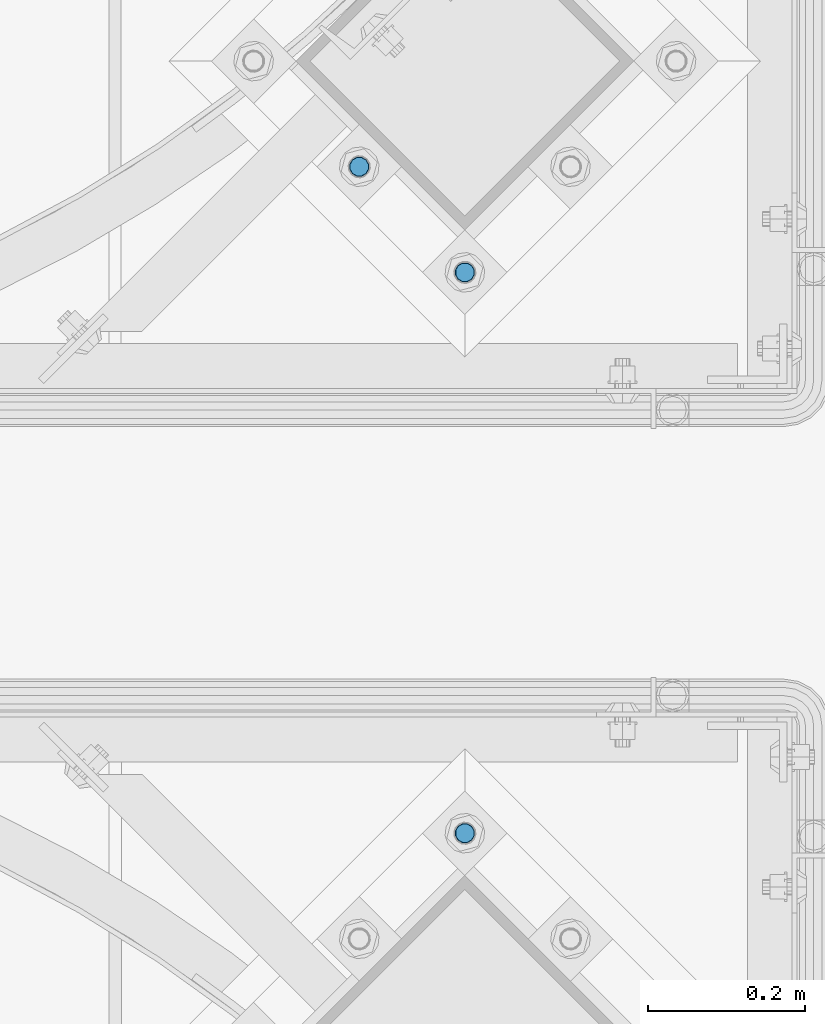
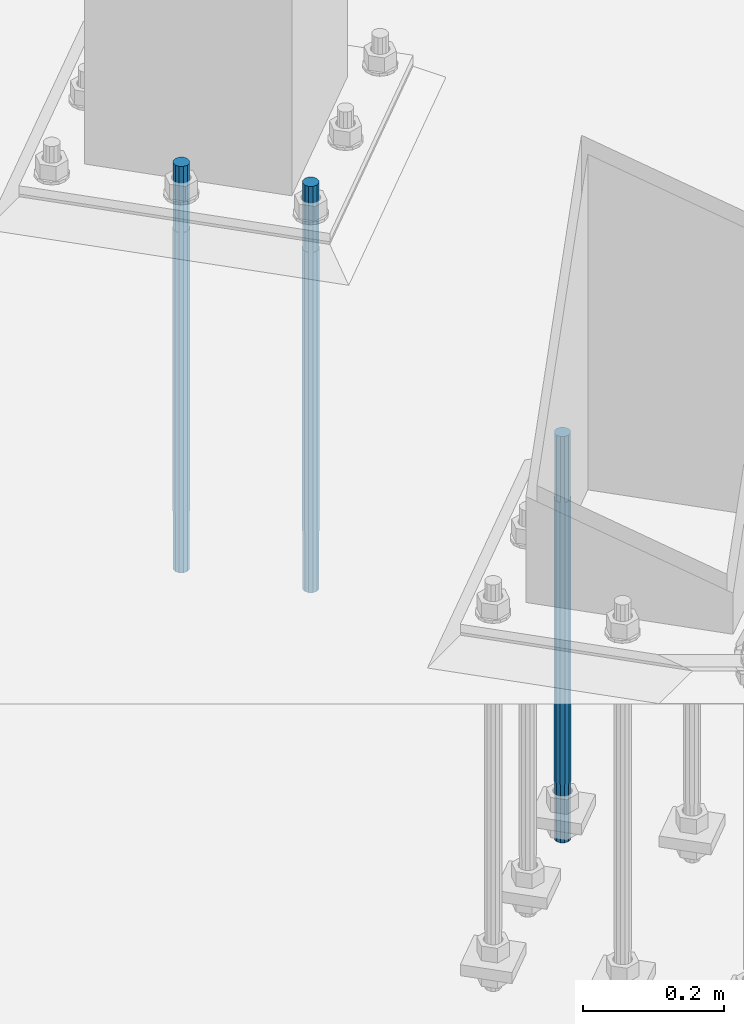
# One storey, part 794 of 1876: 3 columns, 2 elements without a shape of their own.
"""IFC2X3 building model written with IfcOpenShell, lengths in millimetres."""

import ifcopenshell
import ifcopenshell.guid

model = None  # the IFC model being written
_history = None  # IfcOwnerHistory: only IFC2X3 demands one
_inside = {}  # id of a spatial element -> (the spatial element, [elements in it])
_under = {}  # id of a project, library or spatial element -> (it, [spatial elements below it])
_declared = {}  # id of a project -> (the project, [libraries it declares])
_typed = {}  # id of a type object -> (the type object, [elements of that type])
_made_of = {}  # id of a material, layer set ... -> (it, [elements and type objects made of it])


def new_model(schema):
    """Start an empty IFC model of exactly this schema.

    Asked for "IFC4X3", IfcOpenShell would pick the latest addendum, in which some entities
    have other attributes; the version numbers below select the first issue.
    IFC2X3 requires an IfcOwnerHistory on every rooted entity: one is made here for all.
    """
    global model, _history
    if schema == "IFC4X3":
        model = ifcopenshell.file(schema_version=(4, 3, 0, 0))
    else:
        model = ifcopenshell.file(schema=schema)
    _inside.clear()
    _under.clear()
    _declared.clear()
    _typed.clear()
    _made_of.clear()
    _history = None
    if model.schema == "IFC2X3":
        org = make("IfcOrganization", Name="unknown")
        user = make(
            "IfcPersonAndOrganization",
            ThePerson=make("IfcPerson", FamilyName="unknown"),
            TheOrganization=org,
        )
        app = make(
            "IfcApplication",
            ApplicationDeveloper=org,
            Version="unknown",
            ApplicationFullName="unknown",
            ApplicationIdentifier="unknown",
        )
        _history = make(
            "IfcOwnerHistory",
            OwningUser=user,
            OwningApplication=app,
            ChangeAction="ADDED",
            CreationDate=0,
        )
    return model


def make(cls, **values):
    """One entity of the class cls with the attributes given. An attribute that is None is left unset."""
    return model.create_entity(
        cls, **{name: value for name, value in values.items() if value is not None}
    )


def rooted(cls, **values):
    """An entity with a GlobalId (a new one), such as an element, a storey or a relation."""
    return make(cls, GlobalId=ifcopenshell.guid.new(), OwnerHistory=_history, **values)


def si_unit(unit_type, name, prefix=None):
    """IfcSIUnit, for example si_unit("LENGTHUNIT", "METRE", prefix="MILLI")."""
    return make("IfcSIUnit", UnitType=unit_type, Prefix=prefix, Name=name)


def assignment(units):
    """IfcUnitAssignment: the units of a project."""
    return None if units is None else make("IfcUnitAssignment", Units=units)


def point(xyz):
    """IfcCartesianPoint."""
    return None if xyz is None else make("IfcCartesianPoint", Coordinates=xyz)


def direction(xyz):
    """IfcDirection."""
    return None if xyz is None else make("IfcDirection", DirectionRatios=xyz)


def frame(location, z_axis=None, x_axis=None):
    """IfcAxis2Placement3D, a coordinate frame: its origin and axes. An axis left out is left unset."""
    return make(
        "IfcAxis2Placement3D",
        Location=point(location),
        Axis=direction(z_axis),
        RefDirection=direction(x_axis),
    )


def origin_with_axes():
    """The frame at (0, 0, 0) with the z axis (0, 0, 1) and the x axis (1, 0, 0) written out."""
    return frame((0.0, 0.0, 0.0), z_axis=(0.0, 0.0, 1.0), x_axis=(1.0, 0.0, 0.0))


def place(relative_to, where):
    """IfcLocalPlacement: puts the frame where relative to a parent placement (None: the world)."""
    return make(
        "IfcLocalPlacement", PlacementRelTo=relative_to, RelativePlacement=where
    )


def context(
    kind, dimensions, precision=None, world=None, true_north=None, identifier=None
):
    """IfcGeometricRepresentationContext, for example the 3D "Model" context."""
    return make(
        "IfcGeometricRepresentationContext",
        ContextIdentifier=identifier,
        ContextType=kind,
        CoordinateSpaceDimension=dimensions,
        Precision=precision,
        WorldCoordinateSystem=world,
        TrueNorth=true_north,
    )


def subcontext(parent, identifier, kind, view, scale=None):
    """IfcGeometricRepresentationSubContext, for example "Body" below "Model"."""
    return make(
        "IfcGeometricRepresentationSubContext",
        ContextIdentifier=identifier,
        ContextType=kind,
        ParentContext=parent,
        TargetScale=scale,
        TargetView=view,
    )


def project(units=None, contexts=None):
    """IfcProject with its units and contexts."""
    return rooted(
        "IfcProject",
        Name="project",
        RepresentationContexts=contexts,
        UnitsInContext=assignment(units),
    )


def spatial(cls, under=None, at=None, **own):
    """A site, building, storey or space (cls), placed at a placement, below another one or the project."""
    s = rooted(cls, ObjectPlacement=at, **own)
    if under is not None:
        _under.setdefault(under.id(), (under, []))[1].append(s)
    return s


def faces_of(points, faces, orient=None, outer=None):
    """IfcFace entities. A face is a list of loops; a loop is a list of indices into points, from 0.

    orient and outer hold one flag for each loop. By default every Orientation is true, the
    first loop of a face is its IfcFaceOuterBound and the others are IfcFaceBound.
    """
    made = []
    for i, loops in enumerate(faces):
        bounds = []
        for j, loop in enumerate(loops):
            is_outer = j == 0 if outer is None else outer[i][j]
            bounds.append(
                make(
                    "IfcFaceOuterBound" if is_outer else "IfcFaceBound",
                    Bound=make("IfcPolyLoop", Polygon=[points[k] for k in loop]),
                    Orientation=True if orient is None else orient[i][j],
                )
            )
        made.append(make("IfcFace", Bounds=bounds))
    return made


def faceted_brep(points, faces, orient=None, outer=None, voids=None):
    """IfcFacetedBrep: a solid bounded by flat faces; with voids (closed shells), ...WithVoids."""
    shared = [point(p) for p in points]
    hull = make("IfcClosedShell", CfsFaces=faces_of(shared, faces, orient, outer))
    if voids is None:
        return make("IfcFacetedBrep", Outer=hull)
    return make(
        "IfcFacetedBrepWithVoids",
        Outer=hull,
        Voids=[
            make(cls, CfsFaces=faces_of(shared, fs, o, b)) for cls, fs, o, b in voids
        ],
    )


def shape(context_of_items, identifier, shape_type, items):
    """IfcShapeRepresentation: the items that make up one representation, for example the "Body"."""
    return make(
        "IfcShapeRepresentation",
        ContextOfItems=context_of_items,
        RepresentationIdentifier=identifier,
        RepresentationType=shape_type,
        Items=items,
    )


def material(Name=None, Category=None):
    """IfcMaterial."""
    return make("IfcMaterial", Name=Name, Category=Category)


def made_of(thing, what):
    """Note that an element or type object is made of a material, layer set ...; save() writes the relation."""
    if what is not None:
        _made_of.setdefault(what.id(), (what, []))[1].append(thing)
    return thing


def type_object(cls, material=None, **own):
    """A type object (cls), such as IfcWallType, which elements share."""
    return made_of(rooted(cls, **own), material)


def element(
    cls,
    number,
    at=None,
    inside=None,
    cuts=None,
    type_object=None,
    material=None,
    context=None,
    identifier="Body",
    shape_type=None,
    held_by="IfcProductDefinitionShape",
    body=None,
    shapes=None,
    **own,
):
    """One element of the class cls, such as IfcWall. Its Tag is "e" and its number.

    at: its placement. inside: the storey or other place that contains it. cuts: it is an
    opening in that element (IfcRelVoidsElement). A single representation is given by context,
    identifier, shape_type and body (its items); several are given by shapes. held_by: the class
    of the entity that holds the representations. save() writes the other relations.
    """
    e = rooted(cls, Tag="e%d" % number, ObjectPlacement=at, **own)
    if body is not None:
        shapes = [shape(context, identifier, shape_type, body)]
    if shapes is not None:
        e.Representation = make(held_by, Representations=shapes)
    if inside is not None:
        _inside.setdefault(inside.id(), (inside, []))[1].append(e)
    if cuts is not None:
        rooted(
            "IfcRelVoidsElement", RelatingBuildingElement=cuts, RelatedOpeningElement=e
        )
    if type_object is not None:
        _typed.setdefault(type_object.id(), (type_object, []))[1].append(e)
    return made_of(e, material)


def aggregate(whole, parts):
    """IfcRelAggregates: a whole, such as a stair, and the parts it consists of."""
    return rooted("IfcRelAggregates", RelatingObject=whole, RelatedObjects=parts)


def save(model, path):
    """Write the relations noted so far, then the file.

    IfcRelAggregates (storeys below a building ...), IfcRelContainedInSpatialStructure (elements
    in a storey), IfcRelDefinesByType, IfcRelAssociatesMaterial and IfcRelDeclares: one each for
    every whole, place, type object, material and project.
    """
    for whole, parts in _under.values():
        aggregate(whole, parts)
    for where, things in _inside.values():
        rooted(
            "IfcRelContainedInSpatialStructure",
            RelatedElements=things,
            RelatingStructure=where,
        )
    for kind, things in _typed.values():
        rooted("IfcRelDefinesByType", RelatedObjects=things, RelatingType=kind)
    for what, things in _made_of.values():
        rooted("IfcRelAssociatesMaterial", RelatedObjects=things, RelatingMaterial=what)
    for by, libraries in _declared.values():
        rooted("IfcRelDeclares", RelatingContext=by, RelatedDefinitions=libraries)
    model.write(path)


model = new_model("IFC2X3")

# Units and contexts
model_context = context("Model", 3, precision=1e-05, world=origin_with_axes())
body_context = subcontext(model_context, "Body", "Model", "MODEL_VIEW")
ifc_project = project(units=[si_unit("LENGTHUNIT", "METRE", prefix="MILLI"), si_unit("AREAUNIT", "SQUARE_METRE"), si_unit("VOLUMEUNIT", "CUBIC_METRE"), si_unit("MASSUNIT", "GRAM", prefix="KILO"), si_unit("TIMEUNIT", "SECOND"), si_unit("PLANEANGLEUNIT", "RADIAN"), si_unit("SOLIDANGLEUNIT", "STERADIAN"), si_unit("THERMODYNAMICTEMPERATUREUNIT", "DEGREE_CELSIUS"), si_unit("LUMINOUSINTENSITYUNIT", "LUMEN")], contexts=[model_context])

# Site, building, storey
site_placement = place(None, origin_with_axes())
site = spatial("IfcSite", under=ifc_project, at=site_placement, CompositionType="ELEMENT")
building_placement = place(site_placement, origin_with_axes())
building = spatial("IfcBuilding", under=site, at=building_placement, Name="Undefined", CompositionType="ELEMENT")
storey_placement = place(building_placement, origin_with_axes())
storey = spatial("IfcBuildingStorey", under=building, at=storey_placement, Name="Undefined", CompositionType="ELEMENT", Elevation=0.0)

# Assembly, column
assembly_1_placement = place(storey_placement, origin_with_axes())
assembly_1 = element("IfcElementAssembly", 1, at=assembly_1_placement, inside=storey, Name="TEMPLATE", AssemblyPlace="NOTDEFINED", PredefinedType="RIGID_FRAME")
ifc_material = material(Name="STEEL/F1554-GR.105")
column_type = type_object("IfcColumnType", PredefinedType="NOTDEFINED")
column_1_placement = place(assembly_1_placement, frame((6580.27489085662, -11920.9174255113, 7.105427357601e-15), z_axis=(-0.707106781186547, -0.707106781186548, 0.0), x_axis=(0.0, 0.0, -1.0)))
column_1 = element("IfcColumn", 2, at=column_1_placement, type_object=column_type, material=ifc_material, Name="ANCHOR_BOLTS", context=body_context, shape_type="Brep", body=[
    faceted_brep([(-114.3, -10.3923048454853, 6.0000000001337), (-114.3, -6.00000000006912, 10.3923048455481), (-114.3, -6.54836185276508e-11, 12.0000000001355), (-114.3, 5.99999999993634, 10.3923048455481), (-114.3, 10.3923048453526, 6.00000000013279), (-114.3, 11.9999999999418, 1.29148247651756e-10), (-114.3, 10.3923048453507, -5.99999999987358), (-114.3, 5.99999999993815, -10.392304845288), (-114.3, -6.54836185276508e-11, -11.9999999998781), (-114.3, -6.00000000006912, -10.3923048452889), (-114.3, -10.3923048454853, -5.99999999987358), (-114.3, -12.0000000000728, 1.28238752949983e-10), (0.0, 11.9999999999418, 1.29148247651756e-10), (0.0, 10.3923048453507, -5.99999999987358), (0.0, 5.99999999993815, -10.392304845288), (0.0, -6.54836185276508e-11, -11.9999999998781), (0.0, -6.00000000006912, -10.3923048452889), (0.0, -10.3923048454853, -5.99999999987358), (0.0, -12.0000000000728, 1.28238752949983e-10), (0.0, -10.3923048454853, 6.0000000001337), (0.0, -6.00000000006912, 10.3923048455481), (0.0, -6.54836185276508e-11, 12.0000000001355), (0.0, 5.99999999993634, 10.3923048455481), (0.0, 10.3923048453526, 6.00000000013279), (0.0, -10.998522628066, 6.35000000000218), (0.0, -6.35000000000218, 10.9985226280642), (0.0, 0.0, 12.7000000000035), (0.0, 6.34999999999854, 10.9985226280651), (0.0, 10.9985226280623, 6.35000000000218), (0.0, 12.6999999999998, 0.0), (0.0, 10.9985226280623, -6.35000000000127), (0.0, 6.34999999999854, -10.9985226280633), (0.0, 0.0, -12.7000000000016), (0.0, -6.35000000000218, -10.9985226280642), (0.0, -10.998522628066, -6.35000000000127), (0.0, -12.6999999999998, 0.0), (488.95, -12.7000000000044, 9.09494701772928e-13), (488.95, -10.998522628066, 6.35000000000218), (488.95, -6.35000000000218, 10.9985226280642), (488.95, 0.0, 12.7000000000035), (488.95, 6.34999999999854, 10.9985226280651), (488.95, 10.9985226280623, 6.35000000000218), (488.95, 12.7000000000007, 9.09494701772928e-13), (488.95, 10.9985226280623, -6.35000000000127), (488.95, 6.34999999999854, -10.9985226280633), (488.95, 0.0, -12.7000000000016), (488.95, -6.35000000000218, -10.9985226280642), (488.95, -10.998522628066, -6.35000000000127), (488.95, -6.00000000006912, 10.3923048455481), (488.95, -6.54836185276508e-11, 12.0000000001355), (488.95, 5.99999999993634, 10.3923048455481), (488.95, 10.3923048453526, 6.00000000013279), (488.95, 11.9999999999418, 1.29148247651756e-10), (488.95, 10.3923048453507, -5.99999999987358), (488.95, 5.99999999993815, -10.392304845288), (488.95, -6.54836185276508e-11, -11.9999999998781), (488.95, -6.00000000006912, -10.3923048452889), (488.95, -10.3923048454853, -5.99999999987358), (488.95, -12.0000000000728, 1.28238752949983e-10), (488.95, -10.3923048454853, 6.0000000001337), (590.55, -6.00000000006912, -10.3923048452889), (590.55, -6.54836185276508e-11, -11.9999999998781), (590.55, 5.99999999993815, -10.392304845288), (590.55, 10.3923048453507, -5.99999999987358), (590.55, 11.9999999999418, 1.29148247651756e-10), (590.55, 10.3923048453526, 6.00000000013279), (590.55, 5.99999999993634, 10.3923048455481), (590.55, -6.54836185276508e-11, 12.0000000001355), (590.55, -6.00000000006912, 10.3923048455481), (590.55, -10.3923048454853, 6.0000000001337), (590.55, -12.0000000000728, 1.28238752949983e-10), (590.55, -10.3923048454853, -5.99999999987358)], [[[0, 1, 2, 3, 4, 5, 6, 7, 8, 9, 10, 11]], [[6, 5, 12, 13]], [[7, 6, 13, 14]], [[8, 7, 14, 15]], [[9, 8, 15, 16]], [[10, 9, 16, 17]], [[11, 10, 17, 18]], [[0, 11, 18, 19]], [[1, 0, 19, 20]], [[2, 1, 20, 21]], [[3, 2, 21, 22]], [[4, 3, 22, 23]], [[5, 4, 23, 12]], [[24, 25, 26, 27, 28, 29, 30, 31, 32, 33, 34, 35], [22, 21, 20, 19, 18, 17, 16, 15, 14, 13, 12, 23]], [[24, 35, 36, 37]], [[25, 24, 37, 38]], [[26, 25, 38, 39]], [[27, 26, 39, 40]], [[28, 27, 40, 41]], [[29, 28, 41, 42]], [[30, 29, 42, 43]], [[31, 30, 43, 44]], [[32, 31, 44, 45]], [[33, 32, 45, 46]], [[34, 33, 46, 47]], [[35, 34, 47, 36]], [[46, 45, 44, 43, 42, 41, 40, 39, 38, 37, 36, 47], [48, 49, 50, 51, 52, 53, 54, 55, 56, 57, 58, 59]], [[60, 61, 62, 63, 64, 65, 66, 67, 68, 69, 70, 71]], [[68, 67, 49, 48]], [[69, 68, 48, 59]], [[70, 69, 59, 58]], [[71, 70, 58, 57]], [[60, 71, 57, 56]], [[61, 60, 56, 55]], [[62, 61, 55, 54]], [[63, 62, 54, 53]], [[64, 63, 53, 52]], [[65, 64, 52, 51]], [[66, 65, 51, 50]], [[67, 66, 50, 49]]]),
])
aggregate(assembly_1, [column_1])

# Assembly, columns
assembly_2_placement = place(storey_placement, origin_with_axes())
assembly_2 = element("IfcElementAssembly", 3, at=assembly_2_placement, inside=storey, Name="TEMPLATE", AssemblyPlace="NOTDEFINED", PredefinedType="RIGID_FRAME")
column_2_placement = place(assembly_2_placement, frame((6580.27820529301, -11205.6400740426, 7.105427357601e-15), z_axis=(0.707106781186548, 0.707106781186547, 0.0), x_axis=(0.0, 0.0, -1.0)))
column_2 = element("IfcColumn", 4, at=column_2_placement, type_object=column_type, material=ifc_material, Name="ANCHOR_BOLTS", context=body_context, shape_type="Brep", body=[
    faceted_brep([(-114.3, -10.3923048454853, 6.0000000001337), (-114.3, -6.00000000006912, 10.3923048455481), (-114.3, -6.54836185276508e-11, 12.0000000001355), (-114.3, 5.99999999993634, 10.3923048455481), (-114.3, 10.3923048453526, 6.00000000013279), (-114.3, 11.9999999999418, 1.29148247651756e-10), (-114.3, 10.3923048453507, -5.99999999987358), (-114.3, 5.99999999993815, -10.392304845288), (-114.3, -6.54836185276508e-11, -11.9999999998781), (-114.3, -6.00000000006912, -10.3923048452889), (-114.3, -10.3923048454853, -5.99999999987358), (-114.3, -12.0000000000728, 1.28238752949983e-10), (0.0, 11.9999999999418, 1.29148247651756e-10), (0.0, 10.3923048453507, -5.99999999987358), (0.0, 5.99999999993815, -10.392304845288), (0.0, -6.54836185276508e-11, -11.9999999998781), (0.0, -6.00000000006912, -10.3923048452889), (0.0, -10.3923048454853, -5.99999999987358), (0.0, -12.0000000000728, 1.28238752949983e-10), (0.0, -10.3923048454853, 6.0000000001337), (0.0, -6.00000000006912, 10.3923048455481), (0.0, -6.54836185276508e-11, 12.0000000001355), (0.0, 5.99999999993634, 10.3923048455481), (0.0, 10.3923048453526, 6.00000000013279), (0.0, -10.998522628066, 6.35000000000218), (0.0, -6.35000000000218, 10.9985226280642), (0.0, 0.0, 12.7000000000035), (0.0, 6.34999999999854, 10.9985226280651), (0.0, 10.9985226280623, 6.35000000000218), (0.0, 12.6999999999998, 0.0), (0.0, 10.9985226280623, -6.35000000000127), (0.0, 6.34999999999854, -10.9985226280633), (0.0, 0.0, -12.7000000000016), (0.0, -6.35000000000218, -10.9985226280642), (0.0, -10.998522628066, -6.35000000000127), (0.0, -12.6999999999998, 0.0), (488.95, -12.7000000000044, 9.09494701772928e-13), (488.95, -10.998522628066, 6.35000000000218), (488.95, -6.35000000000218, 10.9985226280642), (488.95, 0.0, 12.7000000000035), (488.95, 6.34999999999854, 10.9985226280651), (488.95, 10.9985226280623, 6.35000000000218), (488.95, 12.7000000000007, 9.09494701772928e-13), (488.95, 10.9985226280623, -6.35000000000127), (488.95, 6.34999999999854, -10.9985226280633), (488.95, 0.0, -12.7000000000016), (488.95, -6.35000000000218, -10.9985226280642), (488.95, -10.998522628066, -6.35000000000127), (488.95, -6.00000000006912, 10.3923048455481), (488.95, -6.54836185276508e-11, 12.0000000001355), (488.95, 5.99999999993634, 10.3923048455481), (488.95, 10.3923048453526, 6.00000000013279), (488.95, 11.9999999999418, 1.29148247651756e-10), (488.95, 10.3923048453507, -5.99999999987358), (488.95, 5.99999999993815, -10.392304845288), (488.95, -6.54836185276508e-11, -11.9999999998781), (488.95, -6.00000000006912, -10.3923048452889), (488.95, -10.3923048454853, -5.99999999987358), (488.95, -12.0000000000728, 1.28238752949983e-10), (488.95, -10.3923048454853, 6.0000000001337), (590.55, -6.00000000006912, -10.3923048452889), (590.55, -6.54836185276508e-11, -11.9999999998781), (590.55, 5.99999999993815, -10.392304845288), (590.55, 10.3923048453507, -5.99999999987358), (590.55, 11.9999999999418, 1.29148247651756e-10), (590.55, 10.3923048453526, 6.00000000013279), (590.55, 5.99999999993634, 10.3923048455481), (590.55, -6.54836185276508e-11, 12.0000000001355), (590.55, -6.00000000006912, 10.3923048455481), (590.55, -10.3923048454853, 6.0000000001337), (590.55, -12.0000000000728, 1.28238752949983e-10), (590.55, -10.3923048454853, -5.99999999987358)], [[[0, 1, 2, 3, 4, 5, 6, 7, 8, 9, 10, 11]], [[6, 5, 12, 13]], [[7, 6, 13, 14]], [[8, 7, 14, 15]], [[9, 8, 15, 16]], [[10, 9, 16, 17]], [[11, 10, 17, 18]], [[0, 11, 18, 19]], [[1, 0, 19, 20]], [[2, 1, 20, 21]], [[3, 2, 21, 22]], [[4, 3, 22, 23]], [[5, 4, 23, 12]], [[24, 25, 26, 27, 28, 29, 30, 31, 32, 33, 34, 35], [22, 21, 20, 19, 18, 17, 16, 15, 14, 13, 12, 23]], [[24, 35, 36, 37]], [[25, 24, 37, 38]], [[26, 25, 38, 39]], [[27, 26, 39, 40]], [[28, 27, 40, 41]], [[29, 28, 41, 42]], [[30, 29, 42, 43]], [[31, 30, 43, 44]], [[32, 31, 44, 45]], [[33, 32, 45, 46]], [[34, 33, 46, 47]], [[35, 34, 47, 36]], [[46, 45, 44, 43, 42, 41, 40, 39, 38, 37, 36, 47], [48, 49, 50, 51, 52, 53, 54, 55, 56, 57, 58, 59]], [[60, 61, 62, 63, 64, 65, 66, 67, 68, 69, 70, 71]], [[68, 67, 49, 48]], [[69, 68, 48, 59]], [[70, 69, 59, 58]], [[71, 70, 58, 57]], [[60, 71, 57, 56]], [[61, 60, 56, 55]], [[62, 61, 55, 54]], [[63, 62, 54, 53]], [[64, 63, 53, 52]], [[65, 64, 52, 51]], [[66, 65, 51, 50]], [[67, 66, 50, 49]]]),
])
column_3_placement = place(assembly_2_placement, frame((6445.57436347686, -11070.9362322265, 7.105427357601e-15), z_axis=(0.707106781186548, 0.707106781186547, 0.0), x_axis=(0.0, 0.0, -1.0)))
column_3 = element("IfcColumn", 5, at=column_3_placement, type_object=column_type, material=ifc_material, Name="ANCHOR_BOLTS", context=body_context, shape_type="Brep", body=[
    faceted_brep([(-114.3, -10.3923048454853, 6.0000000001337), (-114.3, -6.00000000006912, 10.3923048455481), (-114.3, -6.54836185276508e-11, 12.0000000001355), (-114.3, 5.99999999993634, 10.3923048455481), (-114.3, 10.3923048453526, 6.00000000013279), (-114.3, 11.9999999999418, 1.29148247651756e-10), (-114.3, 10.3923048453507, -5.99999999987358), (-114.3, 5.99999999993815, -10.392304845288), (-114.3, -6.54836185276508e-11, -11.9999999998781), (-114.3, -6.00000000006912, -10.3923048452889), (-114.3, -10.3923048454853, -5.99999999987358), (-114.3, -12.0000000000728, 1.28238752949983e-10), (0.0, 11.9999999999418, 1.29148247651756e-10), (0.0, 10.3923048453507, -5.99999999987358), (0.0, 5.99999999993815, -10.392304845288), (0.0, -6.54836185276508e-11, -11.9999999998781), (0.0, -6.00000000006912, -10.3923048452889), (0.0, -10.3923048454853, -5.99999999987358), (0.0, -12.0000000000728, 1.28238752949983e-10), (0.0, -10.3923048454853, 6.0000000001337), (0.0, -6.00000000006912, 10.3923048455481), (0.0, -6.54836185276508e-11, 12.0000000001355), (0.0, 5.99999999993634, 10.3923048455481), (0.0, 10.3923048453526, 6.00000000013279), (0.0, -10.998522628066, 6.35000000000218), (0.0, -6.35000000000218, 10.9985226280642), (0.0, 0.0, 12.7000000000035), (0.0, 6.34999999999854, 10.9985226280651), (0.0, 10.9985226280623, 6.35000000000218), (0.0, 12.6999999999998, 0.0), (0.0, 10.9985226280623, -6.35000000000127), (0.0, 6.34999999999854, -10.9985226280633), (0.0, 0.0, -12.7000000000016), (0.0, -6.35000000000218, -10.9985226280642), (0.0, -10.998522628066, -6.35000000000127), (0.0, -12.6999999999998, 0.0), (488.95, -12.7000000000044, 9.09494701772928e-13), (488.95, -10.998522628066, 6.35000000000218), (488.95, -6.35000000000218, 10.9985226280642), (488.95, 0.0, 12.7000000000035), (488.95, 6.34999999999854, 10.9985226280651), (488.95, 10.9985226280623, 6.35000000000218), (488.95, 12.7000000000007, 9.09494701772928e-13), (488.95, 10.9985226280623, -6.35000000000127), (488.95, 6.34999999999854, -10.9985226280633), (488.95, 0.0, -12.7000000000016), (488.95, -6.35000000000218, -10.9985226280642), (488.95, -10.998522628066, -6.35000000000127), (488.95, -6.00000000006912, 10.3923048455481), (488.95, -6.54836185276508e-11, 12.0000000001355), (488.95, 5.99999999993634, 10.3923048455481), (488.95, 10.3923048453526, 6.00000000013279), (488.95, 11.9999999999418, 1.29148247651756e-10), (488.95, 10.3923048453507, -5.99999999987358), (488.95, 5.99999999993815, -10.392304845288), (488.95, -6.54836185276508e-11, -11.9999999998781), (488.95, -6.00000000006912, -10.3923048452889), (488.95, -10.3923048454853, -5.99999999987358), (488.95, -12.0000000000728, 1.28238752949983e-10), (488.95, -10.3923048454853, 6.0000000001337), (590.55, -6.00000000006912, -10.3923048452889), (590.55, -6.54836185276508e-11, -11.9999999998781), (590.55, 5.99999999993815, -10.392304845288), (590.55, 10.3923048453507, -5.99999999987358), (590.55, 11.9999999999418, 1.29148247651756e-10), (590.55, 10.3923048453526, 6.00000000013279), (590.55, 5.99999999993634, 10.3923048455481), (590.55, -6.54836185276508e-11, 12.0000000001355), (590.55, -6.00000000006912, 10.3923048455481), (590.55, -10.3923048454853, 6.0000000001337), (590.55, -12.0000000000728, 1.28238752949983e-10), (590.55, -10.3923048454853, -5.99999999987358)], [[[0, 1, 2, 3, 4, 5, 6, 7, 8, 9, 10, 11]], [[6, 5, 12, 13]], [[7, 6, 13, 14]], [[8, 7, 14, 15]], [[9, 8, 15, 16]], [[10, 9, 16, 17]], [[11, 10, 17, 18]], [[0, 11, 18, 19]], [[1, 0, 19, 20]], [[2, 1, 20, 21]], [[3, 2, 21, 22]], [[4, 3, 22, 23]], [[5, 4, 23, 12]], [[24, 25, 26, 27, 28, 29, 30, 31, 32, 33, 34, 35], [22, 21, 20, 19, 18, 17, 16, 15, 14, 13, 12, 23]], [[24, 35, 36, 37]], [[25, 24, 37, 38]], [[26, 25, 38, 39]], [[27, 26, 39, 40]], [[28, 27, 40, 41]], [[29, 28, 41, 42]], [[30, 29, 42, 43]], [[31, 30, 43, 44]], [[32, 31, 44, 45]], [[33, 32, 45, 46]], [[34, 33, 46, 47]], [[35, 34, 47, 36]], [[46, 45, 44, 43, 42, 41, 40, 39, 38, 37, 36, 47], [48, 49, 50, 51, 52, 53, 54, 55, 56, 57, 58, 59]], [[60, 61, 62, 63, 64, 65, 66, 67, 68, 69, 70, 71]], [[68, 67, 49, 48]], [[69, 68, 48, 59]], [[70, 69, 59, 58]], [[71, 70, 58, 57]], [[60, 71, 57, 56]], [[61, 60, 56, 55]], [[62, 61, 55, 54]], [[63, 62, 54, 53]], [[64, 63, 53, 52]], [[65, 64, 52, 51]], [[66, 65, 51, 50]], [[67, 66, 50, 49]]]),
])
aggregate(assembly_2, [column_2, column_3])

save(model, "model.ifc")
